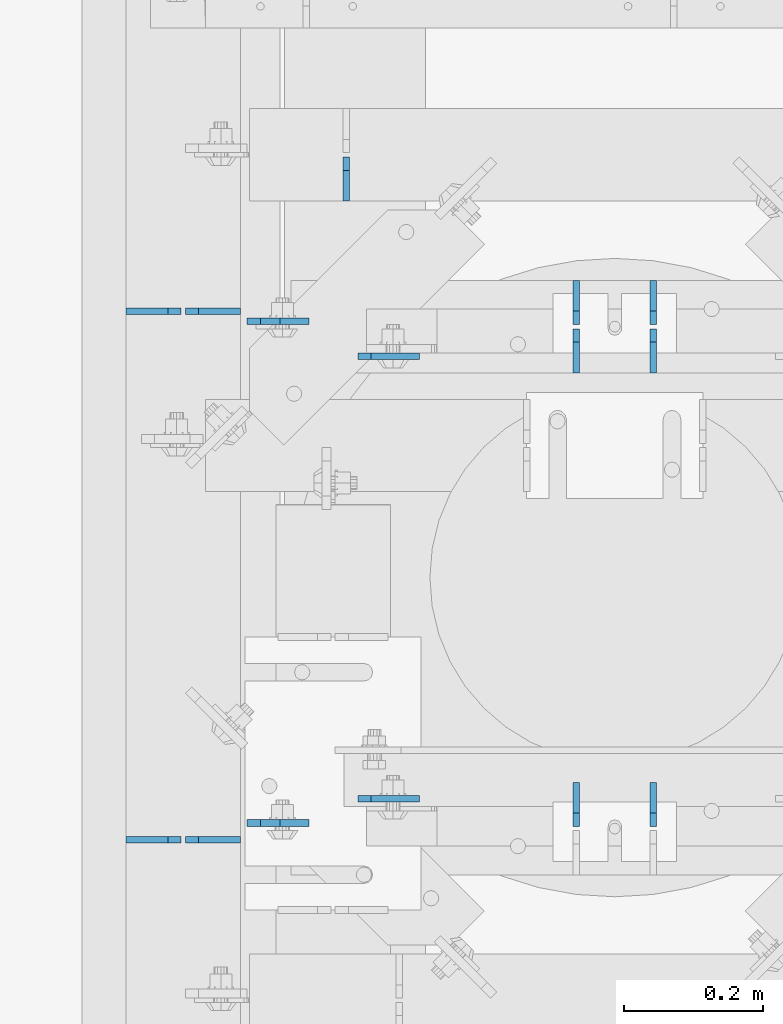
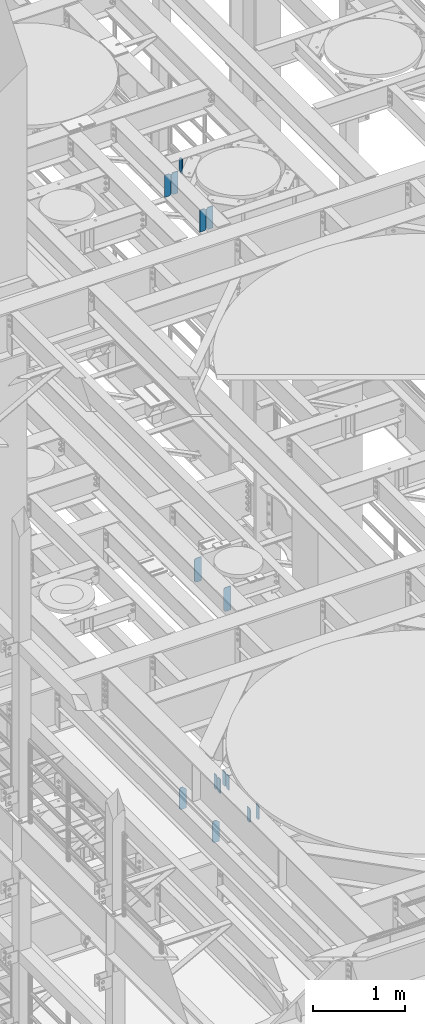
# One storey, part 1638 of 1876: 15 plates, 6 elements without a shape of their own.
"""IFC2X3 building model written with IfcOpenShell, lengths in millimetres."""

from ifc_helpers import new_model, si_unit, frame, origin_with_axes, place, context, subcontext, project, spatial, faceted_brep, material, type_object, element, aggregate, save


model = new_model("IFC2X3")

# Units and contexts
model_context = context("Model", 3, precision=1e-05, world=origin_with_axes())
body_context = subcontext(model_context, "Body", "Model", "MODEL_VIEW")
ifc_project = project(units=[si_unit("LENGTHUNIT", "METRE", prefix="MILLI"), si_unit("AREAUNIT", "SQUARE_METRE"), si_unit("VOLUMEUNIT", "CUBIC_METRE"), si_unit("MASSUNIT", "GRAM", prefix="KILO"), si_unit("TIMEUNIT", "SECOND"), si_unit("PLANEANGLEUNIT", "RADIAN"), si_unit("SOLIDANGLEUNIT", "STERADIAN"), si_unit("THERMODYNAMICTEMPERATUREUNIT", "DEGREE_CELSIUS"), si_unit("LUMINOUSINTENSITYUNIT", "LUMEN")], contexts=[model_context])

# Site, building, storey
site_placement = place(None, origin_with_axes())
site = spatial("IfcSite", under=ifc_project, at=site_placement, CompositionType="ELEMENT")
building_placement = place(site_placement, origin_with_axes())
building = spatial("IfcBuilding", under=site, at=building_placement, Name="Undefined", CompositionType="ELEMENT")
storey_placement = place(building_placement, origin_with_axes())
storey = spatial("IfcBuildingStorey", under=building, at=storey_placement, Name="Undefined", CompositionType="ELEMENT", Elevation=0.0)

# Assembly, plate
assembly_1_placement = place(storey_placement, origin_with_axes())
assembly_1 = element("IfcElementAssembly", 1, at=assembly_1_placement, inside=storey, Name="BEAM", AssemblyPlace="NOTDEFINED", PredefinedType="RIGID_FRAME")
ifc_material = material(Name="STEEL/A36")
plate_type_1 = type_object("IfcPlateType", PredefinedType="NOTDEFINED")
plate_1_placement = place(assembly_1_placement, frame((4032.25, 2984.5, 13111.1625), z_axis=(0.0, 0.0, 1.0), x_axis=(0.0, 1.0, 0.0)))
plate_1 = element("IfcPlate", 2, at=plate_1_placement, type_object=plate_type_1, material=ifc_material, Name="PLATE", context=body_context, shape_type="Brep", body=[
    faceted_brep([(0.0, -4.76249999999982, 0.0), (0.0, -4.76249999999982, 190.5), (0.0, 4.76249999999982, 190.5), (0.0, 4.76249999999982, 0.0), (44.4500007629395, -4.76249999999982, 190.5), (44.4500007629395, 4.76249999999982, 190.5), (63.5, -4.76249999999982, 171.450000762939), (63.5, 4.76249999999982, 171.450000762939), (63.5, -4.76249999999982, 19.0499992370605), (63.5, 4.76249999999982, 19.0499992370605), (44.4500007629395, -4.76249999999982, 0.0), (44.4500007629395, 4.76249999999982, 0.0)], [[[0, 1, 2, 3]], [[1, 4, 5, 2]], [[4, 6, 7, 5]], [[6, 8, 9, 7]], [[8, 10, 11, 9]], [[10, 0, 3, 11]], [[5, 7, 9, 11, 3, 2]], [[10, 8, 6, 4, 1, 0]]]),
])
aggregate(assembly_1, [plate_1])

# Assembly, plates
assembly_2_placement = place(storey_placement, origin_with_axes())
assembly_2 = element("IfcElementAssembly", 3, at=assembly_2_placement, inside=storey, Name="BEAM", AssemblyPlace="NOTDEFINED", PredefinedType="RIGID_FRAME")
plate_2_placement = place(assembly_2_placement, frame((4364.038, 2870.2, 5122.8625), z_axis=(0.0, 0.0, -1.0), x_axis=(0.0, -1.0, 0.0)))
plate_2 = element("IfcPlate", 4, at=plate_2_placement, type_object=plate_type_1, material=ifc_material, Name="PLATE", context=body_context, shape_type="Brep", body=[
    faceted_brep([(0.0, -4.76249999999982, 0.0), (0.0, -4.76249999999982, 190.5), (0.0, 4.76249999999982, 190.5), (0.0, 4.76249999999982, 0.0), (44.4500007629395, -4.76249999999982, 190.5), (44.4500007629395, 4.76249999999982, 190.5), (63.5, -4.76249999999982, 171.450000762939), (63.5, 4.76249999999982, 171.450000762939), (63.5, -4.76249999999982, 19.0499992370605), (63.5, 4.76249999999982, 19.0499992370605), (44.4500007629395, -4.76249999999982, 0.0), (44.4500007629395, 4.76249999999982, 0.0)], [[[0, 1, 2, 3]], [[1, 4, 5, 2]], [[4, 6, 7, 5]], [[6, 8, 9, 7]], [[8, 10, 11, 9]], [[10, 0, 3, 11]], [[5, 7, 9, 11, 3, 2]], [[10, 8, 6, 4, 1, 0]]]),
])
plate_3_placement = place(assembly_2_placement, frame((4475.1625, 2870.2, 5122.8625), z_axis=(0.0, 0.0, -1.0), x_axis=(0.0, -1.0, 0.0)))
plate_3 = element("IfcPlate", 5, at=plate_3_placement, type_object=plate_type_1, material=ifc_material, Name="PLATE", context=body_context, shape_type="Brep", body=[
    faceted_brep([(0.0, -4.76249999999982, 0.0), (0.0, -4.76249999999982, 190.5), (0.0, 4.76249999999982, 190.5), (0.0, 4.76249999999982, 0.0), (44.4500007629395, -4.76249999999982, 190.5), (44.4500007629395, 4.76249999999982, 190.5), (63.5, -4.76249999999982, 171.450000762939), (63.5, 4.76249999999982, 171.450000762939), (63.5, -4.76249999999982, 19.0499992370605), (63.5, 4.76249999999982, 19.0499992370605), (44.4500007629395, -4.76249999999982, 0.0), (44.4500007629395, 4.76249999999982, 0.0)], [[[0, 1, 2, 3]], [[1, 4, 5, 2]], [[4, 6, 7, 5]], [[6, 8, 9, 7]], [[8, 10, 11, 9]], [[10, 0, 3, 11]], [[5, 7, 9, 11, 3, 2]], [[10, 8, 6, 4, 1, 0]]]),
])
plate_4_placement = place(assembly_2_placement, frame((4364.038, 2800.35, 5122.8625), z_axis=(0.0, 0.0, -1.0), x_axis=(0.0, -1.0, 0.0)))
plate_4 = element("IfcPlate", 6, at=plate_4_placement, type_object=plate_type_1, material=ifc_material, Name="PLATE", context=body_context, shape_type="Brep", body=[
    faceted_brep([(0.0, -4.76249999999982, 19.0499992370605), (0.0, -4.76249999999982, 171.450000762939), (0.0, 4.76249999999982, 171.450000762939), (0.0, 4.76249999999982, 19.0499992370605), (19.0499992370605, -4.76249999999982, 190.5), (19.0499992370605, 4.76249999999982, 190.5), (63.5, -4.76249999999982, 190.5), (63.5, 4.76249999999982, 190.5), (63.5, -4.76249999999982, 0.0), (63.5, 4.76249999999982, 0.0), (19.0499992370605, -4.76249999999982, 0.0), (19.0499992370605, 4.76249999999982, 0.0)], [[[0, 1, 2, 3]], [[1, 4, 5, 2]], [[4, 6, 7, 5]], [[6, 8, 9, 7]], [[8, 10, 11, 9]], [[10, 0, 3, 11]], [[5, 7, 9, 11, 3, 2]], [[10, 8, 6, 4, 1, 0]]]),
])
plate_5_placement = place(assembly_2_placement, frame((4475.1625, 2800.35, 5122.8625), z_axis=(0.0, 0.0, -1.0), x_axis=(0.0, -1.0, 0.0)))
plate_5 = element("IfcPlate", 7, at=plate_5_placement, type_object=plate_type_1, material=ifc_material, Name="PLATE", context=body_context, shape_type="Brep", body=[
    faceted_brep([(0.0, -4.76249999999982, 19.0499992370605), (0.0, -4.76249999999982, 171.450000762939), (0.0, 4.76249999999982, 171.450000762939), (0.0, 4.76249999999982, 19.0499992370605), (19.0499992370605, -4.76249999999982, 190.5), (19.0499992370605, 4.76249999999982, 190.5), (63.5, -4.76249999999982, 190.5), (63.5, 4.76249999999982, 190.5), (63.5, -4.76249999999982, 0.0), (63.5, 4.76249999999982, 0.0), (19.0499992370605, -4.76249999999982, 0.0), (19.0499992370605, 4.76249999999982, 0.0)], [[[0, 1, 2, 3]], [[1, 4, 5, 2]], [[4, 6, 7, 5]], [[6, 8, 9, 7]], [[8, 10, 11, 9]], [[10, 0, 3, 11]], [[5, 7, 9, 11, 3, 2]], [[10, 8, 6, 4, 1, 0]]]),
])
aggregate(assembly_2, [plate_2, plate_3, plate_4, plate_5])

assembly_3_placement = place(storey_placement, origin_with_axes())
assembly_3 = element("IfcElementAssembly", 8, at=assembly_3_placement, inside=storey, Name="BEAM", AssemblyPlace="NOTDEFINED", PredefinedType="RIGID_FRAME")
plate_6_placement = place(assembly_3_placement, frame((4364.0375, 2082.8, 4932.3625), z_axis=(0.0, 0.0, 1.0), x_axis=(0.0, 1.0, 0.0)))
plate_6 = element("IfcPlate", 9, at=plate_6_placement, type_object=plate_type_1, material=ifc_material, Name="PLATE", context=body_context, shape_type="Brep", body=[
    faceted_brep([(0.0, -4.76249999999982, 19.0499992370605), (0.0, -4.76249999999982, 171.450000762939), (0.0, 4.76249999999982, 171.450000762939), (0.0, 4.76249999999982, 19.0499992370605), (19.0499992370605, -4.76249999999982, 190.5), (19.0499992370605, 4.76249999999982, 190.5), (63.5, -4.76249999999982, 190.5), (63.5, 4.76249999999982, 190.5), (63.5, -4.76249999999982, 0.0), (63.5, 4.76249999999982, 0.0), (19.0499992370605, -4.76249999999982, 0.0), (19.0499992370605, 4.76249999999982, 0.0)], [[[0, 1, 2, 3]], [[1, 4, 5, 2]], [[4, 6, 7, 5]], [[6, 8, 9, 7]], [[8, 10, 11, 9]], [[10, 0, 3, 11]], [[5, 7, 9, 11, 3, 2]], [[10, 8, 6, 4, 1, 0]]]),
])
plate_7_placement = place(assembly_3_placement, frame((4475.1625, 2082.8, 4932.3625), z_axis=(0.0, 0.0, 1.0), x_axis=(0.0, 1.0, 0.0)))
plate_7 = element("IfcPlate", 10, at=plate_7_placement, type_object=plate_type_1, material=ifc_material, Name="PLATE", context=body_context, shape_type="Brep", body=[
    faceted_brep([(0.0, -4.76249999999982, 19.0499992370605), (0.0, -4.76249999999982, 171.450000762939), (0.0, 4.76249999999982, 171.450000762939), (0.0, 4.76249999999982, 19.0499992370605), (19.0499992370605, -4.76249999999982, 190.5), (19.0499992370605, 4.76249999999982, 190.5), (63.5, -4.76249999999982, 190.5), (63.5, 4.76249999999982, 190.5), (63.5, -4.76249999999982, 0.0), (63.5, 4.76249999999982, 0.0), (19.0499992370605, -4.76249999999982, 0.0), (19.0499992370605, 4.76249999999982, 0.0)], [[[0, 1, 2, 3]], [[1, 4, 5, 2]], [[4, 6, 7, 5]], [[6, 8, 9, 7]], [[8, 10, 11, 9]], [[10, 0, 3, 11]], [[5, 7, 9, 11, 3, 2]], [[10, 8, 6, 4, 1, 0]]]),
])
aggregate(assembly_3, [plate_6, plate_7])

assembly_4_placement = place(storey_placement, origin_with_axes())
assembly_4 = element("IfcElementAssembly", 11, at=assembly_4_placement, inside=storey, Name="BEAM", AssemblyPlace="NOTDEFINED", PredefinedType="RIGID_FRAME")
plate_type_2 = type_object("IfcPlateType", PredefinedType="NOTDEFINED")
plate_8_placement = place(assembly_4_placement, frame((4048.91837964162, 2122.48532657623, 7821.6125), z_axis=(0.0, 0.0, 1.0), x_axis=(1.0, 0.0, 0.0)))
plate_8 = element("IfcPlate", 12, at=plate_8_placement, type_object=plate_type_2, material=ifc_material, Name="PLATE", context=body_context, shape_type="Brep", body=[
    faceted_brep([(0.0, -4.76249999999982, 19.0499992370605), (-1.81898940354586e-12, -4.76250000000073, 296.862499237061), (0.0, 4.76249999999982, 296.862499237061), (0.0, 4.76249999999982, 19.0499992370605), (19.0499992370605, -4.76249999999982, 315.912506103516), (19.0499992370605, 4.76249999999982, 315.912506103516), (88.9000015258789, -4.76249999999982, 315.912506103516), (88.9000015258789, 4.76249999999982, 315.912506103516), (88.9000015258789, -4.76249999999982, 0.0), (88.9000015258789, 4.76249999999982, 0.0), (19.0499992370605, -4.76249999999982, 0.0), (19.0499992370605, 4.76249999999982, 0.0)], [[[0, 1, 2, 3]], [[1, 4, 5, 2]], [[4, 6, 7, 5]], [[6, 8, 9, 7]], [[8, 10, 11, 9]], [[10, 0, 3, 11]], [[5, 7, 9, 11, 3, 2]], [[10, 8, 6, 4, 1, 0]]]),
])
plate_9_placement = place(assembly_4_placement, frame((4048.91837964162, 2760.65916805267, 7821.6125), z_axis=(0.0, 0.0, 1.0), x_axis=(1.0, 0.0, 0.0)))
plate_9 = element("IfcPlate", 13, at=plate_9_placement, type_object=plate_type_2, material=ifc_material, Name="PLATE", context=body_context, shape_type="Brep", body=[
    faceted_brep([(0.0, -4.76249999999982, 19.0499992370605), (-1.81898940354586e-12, -4.76250000000073, 296.862499237061), (0.0, 4.76249999999982, 296.862499237061), (0.0, 4.76249999999982, 19.0499992370605), (19.0499992370605, -4.76249999999982, 315.912506103516), (19.0499992370605, 4.76249999999982, 315.912506103516), (88.9000015258789, -4.76249999999982, 315.912506103516), (88.9000015258789, 4.76249999999982, 315.912506103516), (88.9000015258789, -4.76249999999982, 0.0), (88.9000015258789, 4.76249999999982, 0.0), (19.0499992370605, -4.76249999999982, 0.0), (19.0499992370605, 4.76249999999982, 0.0)], [[[0, 1, 2, 3]], [[1, 4, 5, 2]], [[4, 6, 7, 5]], [[6, 8, 9, 7]], [[8, 10, 11, 9]], [[10, 0, 3, 11]], [[5, 7, 9, 11, 3, 2]], [[10, 8, 6, 4, 1, 0]]]),
])
aggregate(assembly_4, [plate_8, plate_9])

assembly_5_placement = place(storey_placement, origin_with_axes())
assembly_5 = element("IfcElementAssembly", 14, at=assembly_5_placement, inside=storey, Name="BEAM", AssemblyPlace="NOTDEFINED", PredefinedType="RIGID_FRAME")
plate_10_placement = place(assembly_5_placement, frame((3889.375, 2087.56299991608, 4833.9375), z_axis=(0.0, 0.0, 1.0), x_axis=(1.0, 0.0, 0.0)))
plate_10 = element("IfcPlate", 15, at=plate_10_placement, type_object=plate_type_2, material=ifc_material, Name="PLATE", context=body_context, shape_type="Brep", body=[
    faceted_brep([(0.0, -4.76249999999982, 271.462512969971), (19.0499992370605, -4.76249999999982, 290.512512207031), (19.0499992370605, 4.76249999999982, 290.512512207031), (0.0, 4.76249999999982, 271.462512969971), (0.0, -4.76249999999982, 19.0499992370605), (0.0, 4.76249999999982, 19.0499992370605), (19.0499992370605, -4.76249999999982, 0.0), (19.0499992370605, 4.76249999999982, 0.0), (88.9000015258789, -4.76249999999982, 0.0), (88.9000015258789, 4.76249999999982, 0.0), (88.9000015258789, -4.76250000000005, 249.237512489713), (47.6249880912173, -4.76250000000005, 290.512512207031), (47.6249880912173, 4.76250000000005, 290.512512207031), (88.9000015258789, 4.76250000000005, 249.237512489713)], [[[0, 1, 2, 3]], [[4, 0, 3, 5]], [[6, 4, 5, 7]], [[8, 6, 7, 9]], [[1, 0, 4, 6, 8, 10, 11]], [[2, 1, 11, 12]], [[9, 7, 5, 3, 2, 12, 13]], [[8, 9, 13, 10]], [[12, 11, 10, 13]]]),
])
plate_11_placement = place(assembly_5_placement, frame((3889.375, 2811.46299991608, 4833.9375), z_axis=(0.0, 0.0, 1.0), x_axis=(1.0, 0.0, 0.0)))
plate_11 = element("IfcPlate", 16, at=plate_11_placement, type_object=plate_type_2, material=ifc_material, Name="PLATE", context=body_context, shape_type="Brep", body=[
    faceted_brep([(0.0, -4.76249999999982, 271.462512969971), (19.0499992370605, -4.76249999999982, 290.512512207031), (19.0499992370605, 4.76249999999982, 290.512512207031), (0.0, 4.76249999999982, 271.462512969971), (0.0, -4.76249999999982, 19.0499992370605), (0.0, 4.76249999999982, 19.0499992370605), (19.0499992370605, -4.76249999999982, 0.0), (19.0499992370605, 4.76249999999982, 0.0), (88.9000015258789, -4.76249999999982, 0.0), (88.9000015258789, 4.76249999999982, 0.0), (88.9000015258789, -4.76250000000005, 249.237512489713), (47.6249880912173, -4.76250000000005, 290.512512207031), (47.6249880912173, 4.76250000000005, 290.512512207031), (88.9000015258789, 4.76250000000005, 249.237512489713)], [[[0, 1, 2, 3]], [[4, 0, 3, 5]], [[6, 4, 5, 7]], [[8, 6, 7, 9]], [[1, 0, 4, 6, 8, 10, 11]], [[2, 1, 11, 12]], [[9, 7, 5, 3, 2, 12, 13]], [[8, 9, 13, 10]], [[12, 11, 10, 13]]]),
])
aggregate(assembly_5, [plate_10, plate_11])

assembly_6_placement = place(storey_placement, origin_with_axes())
assembly_6 = element("IfcElementAssembly", 17, at=assembly_6_placement, inside=storey, Name="BEAM", AssemblyPlace="NOTDEFINED", PredefinedType="RIGID_FRAME")
plate_type_3 = type_object("IfcPlateType", PredefinedType="NOTDEFINED")
plate_12_placement = place(assembly_6_placement, frame((3879.85, 2825.75, 13006.3875), z_axis=(0.0, 0.0, 1.0), x_axis=(-1.0, 0.0, 0.0)))
plate_12 = element("IfcPlate", 18, at=plate_12_placement, type_object=plate_type_3, material=ifc_material, Name="PLATE", context=body_context, shape_type="Brep", body=[
    faceted_brep([(0.0, -4.76249999999982, 0.0), (0.0, -4.76249999999982, 292.100006103516), (0.0, 4.76249999999982, 292.100006103516), (0.0, 4.76249999999982, 0.0), (60.3250007629395, -4.76249999999982, 292.100006103516), (60.3250007629395, 4.76249999999982, 292.100006103516), (79.375, -4.76249999999982, 273.050006866455), (79.375, 4.76249999999982, 273.050006866455), (79.375, -4.76249999999982, 19.0499992370605), (79.375, 4.76249999999982, 19.0499992370605), (60.3250007629395, -4.76249999999982, 0.0), (60.3250007629395, 4.76249999999982, 0.0)], [[[0, 1, 2, 3]], [[1, 4, 5, 2]], [[4, 6, 7, 5]], [[6, 8, 9, 7]], [[8, 10, 11, 9]], [[10, 0, 3, 11]], [[5, 7, 9, 11, 3, 2]], [[10, 8, 6, 4, 1, 0]]]),
])
plate_13_placement = place(assembly_6_placement, frame((3794.125, 2825.75, 13006.3875), z_axis=(0.0, 0.0, 1.0), x_axis=(-1.0, 0.0, 0.0)))
plate_13 = element("IfcPlate", 19, at=plate_13_placement, type_object=plate_type_3, material=ifc_material, Name="PLATE", context=body_context, shape_type="Brep", body=[
    faceted_brep([(0.0, -4.76249999999982, 19.0499992370605), (0.0, -4.76249999999982, 273.050006866455), (0.0, 4.76249999999982, 273.050006866455), (0.0, 4.76249999999982, 19.0499992370605), (19.0499992370605, -4.76249999999982, 292.100006103516), (19.0499992370605, 4.76249999999982, 292.100006103516), (79.375, -4.76249999999982, 292.100006103516), (79.375, 4.76249999999982, 292.100006103516), (79.375, -4.76250000000073, 0.0), (79.375, 4.76250000000073, 0.0), (19.0499992370605, -4.76249999999982, 0.0), (19.0499992370605, 4.76249999999982, 0.0)], [[[0, 1, 2, 3]], [[1, 4, 5, 2]], [[4, 6, 7, 5]], [[6, 8, 9, 7]], [[8, 10, 11, 9]], [[10, 0, 3, 11]], [[5, 7, 9, 11, 3, 2]], [[10, 8, 6, 4, 1, 0]]]),
])
plate_14_placement = place(assembly_6_placement, frame((3879.85, 2063.75, 13006.3875), z_axis=(0.0, 0.0, 1.0), x_axis=(-1.0, 0.0, 0.0)))
plate_14 = element("IfcPlate", 20, at=plate_14_placement, type_object=plate_type_3, material=ifc_material, Name="PLATE", context=body_context, shape_type="Brep", body=[
    faceted_brep([(0.0, -4.76249999999982, 0.0), (0.0, -4.76249999999982, 292.100006103516), (0.0, 4.76249999999982, 292.100006103516), (0.0, 4.76249999999982, 0.0), (60.3250007629395, -4.76249999999982, 292.100006103516), (60.3250007629395, 4.76249999999982, 292.100006103516), (79.375, -4.76249999999982, 273.050006866455), (79.375, 4.76249999999982, 273.050006866455), (79.375, -4.76249999999982, 19.0499992370605), (79.375, 4.76249999999982, 19.0499992370605), (60.3250007629395, -4.76249999999982, 0.0), (60.3250007629395, 4.76249999999982, 0.0)], [[[0, 1, 2, 3]], [[1, 4, 5, 2]], [[4, 6, 7, 5]], [[6, 8, 9, 7]], [[8, 10, 11, 9]], [[10, 0, 3, 11]], [[5, 7, 9, 11, 3, 2]], [[10, 8, 6, 4, 1, 0]]]),
])
plate_15_placement = place(assembly_6_placement, frame((3794.125, 2063.75, 13006.3875), z_axis=(0.0, 0.0, 1.0), x_axis=(-1.0, 0.0, 0.0)))
plate_15 = element("IfcPlate", 21, at=plate_15_placement, type_object=plate_type_3, material=ifc_material, Name="PLATE", context=body_context, shape_type="Brep", body=[
    faceted_brep([(0.0, -4.76249999999982, 19.0499992370605), (0.0, -4.76249999999982, 273.050006866455), (0.0, 4.76249999999982, 273.050006866455), (0.0, 4.76249999999982, 19.0499992370605), (19.0499992370605, -4.76249999999982, 292.100006103516), (19.0499992370605, 4.76249999999982, 292.100006103516), (79.375, -4.76249999999982, 292.100006103516), (79.375, 4.76249999999982, 292.100006103516), (79.375, -4.76250000000073, 0.0), (79.375, 4.76250000000073, 0.0), (19.0499992370605, -4.76249999999982, 0.0), (19.0499992370605, 4.76249999999982, 0.0)], [[[0, 1, 2, 3]], [[1, 4, 5, 2]], [[4, 6, 7, 5]], [[6, 8, 9, 7]], [[8, 10, 11, 9]], [[10, 0, 3, 11]], [[5, 7, 9, 11, 3, 2]], [[10, 8, 6, 4, 1, 0]]]),
])
aggregate(assembly_6, [plate_12, plate_13, plate_14, plate_15])

save(model, "model.ifc")
